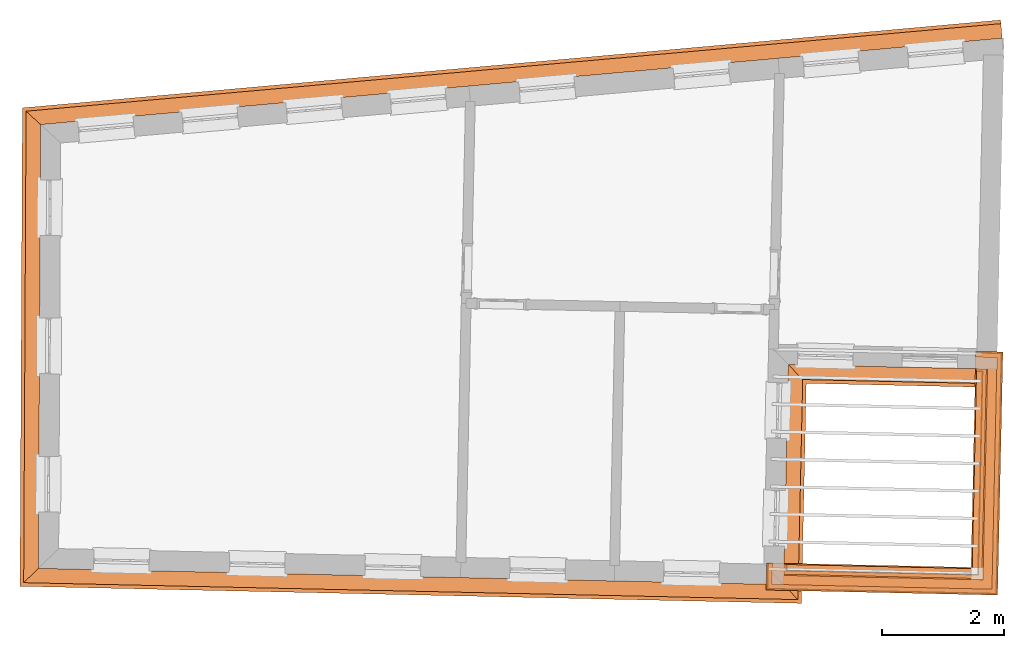
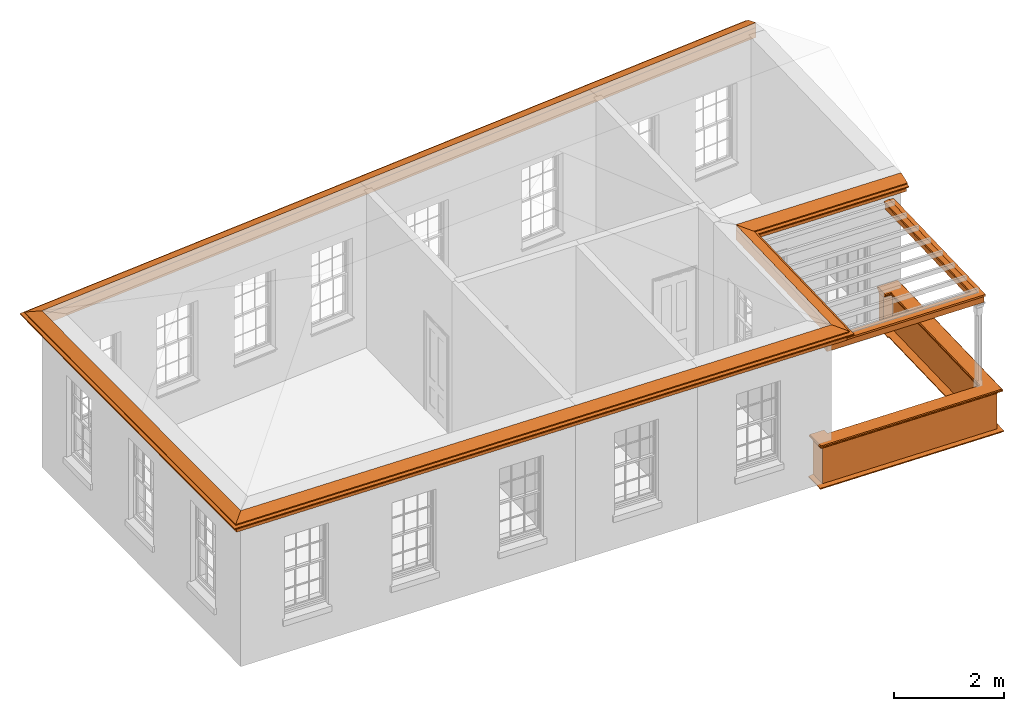
# One storey, part 13 of 14: 7 proxies.
"""IFC2X3 building model written with IfcOpenShell, lengths in metres."""

from ifc_helpers import new_model, entity, si_unit, frame, origin, place, context, subcontext, project, spatial, element, save


model = new_model("IFC2X3")

# Units and contexts
model_context = context("Model", 3, world=origin())
body_context = subcontext(model_context, "Body", "Model", "MODEL_VIEW")
ifc_project = project(units=[si_unit("PLANEANGLEUNIT", "RADIAN"), si_unit("MASSUNIT", "GRAM", prefix="KILO"), si_unit("FORCEUNIT", "NEWTON", prefix="KILO"), si_unit("LENGTHUNIT", "METRE")], contexts=[model_context])

# Site, building, storey
site_placement = place(None, origin())
site = spatial("IfcSite", under=ifc_project, at=site_placement, CompositionType="ELEMENT")
building_placement = place(None, origin())
building = spatial("IfcBuilding", under=site, at=building_placement, Name="Building plot-17", CompositionType="ELEMENT")
storey_placement = place(None, frame((0.0, 0.0, 6.15)))
storey = spatial("IfcBuildingStorey", under=building, at=storey_placement, Name="Floor 1", CompositionType="ELEMENT", Elevation=6.15)

# Proxies
proxy_1_placement = place(storey_placement, frame((0.0, 0.0, 3.45)))
axis2_placement3_d_1 = entity("IfcAxis2Placement3D", entity("IfcCartesianPoint", [0.0, 0.0, 0.0]))
element("IfcBuildingElementProxy", 1, at=proxy_1_placement, inside=storey, Name="eaves", CompositionType="ELEMENT", context=body_context, shape_type="SweptSolid", held_by="IfcProductRepresentation", body=[
    entity("IfcSurfaceCurveSweptAreaSolid", entity("IfcArbitraryClosedProfileDef", "AREA", None, entity("IfcPolyline", [entity("IfcCartesianPoint", [-0.11, 0.25]), entity("IfcCartesianPoint", [-0.33, 0.25]), entity("IfcCartesianPoint", [-0.33, 0.265]), entity("IfcCartesianPoint", [-0.318, 0.268]), entity("IfcCartesianPoint", [-0.309, 0.274]), entity("IfcCartesianPoint", [-0.303, 0.283]), entity("IfcCartesianPoint", [-0.3, 0.295]), entity("IfcCartesianPoint", [-0.285, 0.295]), entity("IfcCartesianPoint", [-0.285, 0.455]), entity("IfcCartesianPoint", [-0.205, 0.455]), entity("IfcCartesianPoint", [-0.205, 0.47]), entity("IfcCartesianPoint", [-0.19, 0.47]), entity("IfcCartesianPoint", [-0.189, 0.483]), entity("IfcCartesianPoint", [-0.186, 0.494]), entity("IfcCartesianPoint", [-0.179, 0.506]), entity("IfcCartesianPoint", [-0.17, 0.514]), entity("IfcCartesianPoint", [-0.16, 0.52]), entity("IfcCartesianPoint", [-0.149, 0.529]), entity("IfcCartesianPoint", [-0.143, 0.539]), entity("IfcCartesianPoint", [-0.14, 0.55]), entity("IfcCartesianPoint", [-0.12, 0.55]), entity("IfcCartesianPoint", [-0.11, 0.48]), entity("IfcCartesianPoint", [-0.11, 0.25])])), axis2_placement3_d_1, entity("IfcPolyline", [entity("IfcCartesianPoint", [86.1735333873012, 26.9244980470085]), entity("IfcCartesianPoint", [70.6604159338027, 25.5310649283099]), entity("IfcCartesianPoint", [70.6259364838392, 18.7410401401183]), entity("IfcCartesianPoint", [82.327616740338, 18.4850974377815]), entity("IfcCartesianPoint", [82.4063929700334, 22.086740474646]), entity("IfcCartesianPoint", [86.0675204491048, 22.0066631831756])]), 0.0, 1.0, entity("IfcPlane", axis2_placement3_d_1)),
])
proxy_2_placement = place(storey_placement, frame((0.0, 0.0, 3.45)))
axis2_placement3_d_2 = entity("IfcAxis2Placement3D", entity("IfcCartesianPoint", [0.0, 0.0, 0.0]))
element("IfcBuildingElementProxy", 2, at=proxy_2_placement, inside=storey, Name="eaves", CompositionType="ELEMENT", context=body_context, shape_type="SweptSolid", held_by="IfcProductRepresentation", body=[
    entity("IfcSurfaceCurveSweptAreaSolid", entity("IfcArbitraryClosedProfileDef", "AREA", None, entity("IfcPolyline", [entity("IfcCartesianPoint", [-0.11, 0.25]), entity("IfcCartesianPoint", [-0.11, 0.48]), entity("IfcCartesianPoint", [-0.08, 0.49]), entity("IfcCartesianPoint", [0.0, 0.25]), entity("IfcCartesianPoint", [-0.11, 0.25])])), axis2_placement3_d_2, entity("IfcPolyline", [entity("IfcCartesianPoint", [86.1735333873012, 26.9244980470085]), entity("IfcCartesianPoint", [70.6604159338027, 25.5310649283099]), entity("IfcCartesianPoint", [70.6259364838392, 18.7410401401183]), entity("IfcCartesianPoint", [82.327616740338, 18.4850974377815]), entity("IfcCartesianPoint", [82.4063929700334, 22.086740474646]), entity("IfcCartesianPoint", [86.0675204491048, 22.0066631831756])]), 0.0, 1.0, entity("IfcPlane", axis2_placement3_d_2)),
])
proxy_3_placement = place(storey_placement, origin())
axis2_placement3_d_3 = entity("IfcAxis2Placement3D", entity("IfcCartesianPoint", [0.0, 0.0, 0.0]))
element("IfcBuildingElementProxy", 3, at=proxy_3_placement, inside=storey, Name="parapet", CompositionType="ELEMENT", context=body_context, shape_type="SweptSolid", held_by="IfcProductRepresentation", body=[
    entity("IfcSurfaceCurveSweptAreaSolid", entity("IfcArbitraryClosedProfileDef", "AREA", None, entity("IfcPolyline", [entity("IfcCartesianPoint", [0.0, 0.25]), entity("IfcCartesianPoint", [0.795, 0.25]), entity("IfcCartesianPoint", [0.795, 0.09]), entity("IfcCartesianPoint", [0.02, 0.09]), entity("IfcCartesianPoint", [0.02, -0.08]), entity("IfcCartesianPoint", [0.0, -0.08]), entity("IfcCartesianPoint", [0.0, 0.25])])), axis2_placement3_d_3, entity("IfcPolyline", [entity("IfcCartesianPoint", [82.6397293226527, 18.5782947336697]), entity("IfcCartesianPoint", [82.6375426152953, 18.4783186449738]), entity("IfcCartesianPoint", [85.7388039976697, 18.4104869147044]), entity("IfcCartesianPoint", [85.8108014345573, 21.7022040766116]), entity("IfcCartesianPoint", [85.7108253458614, 21.7043907839689])]), 0.0, 1.0, entity("IfcPlane", axis2_placement3_d_3)),
])
proxy_4_placement = place(storey_placement, origin())
axis2_placement3_d_4 = entity("IfcAxis2Placement3D", entity("IfcCartesianPoint", [0.0, 0.0, 0.0]))
element("IfcBuildingElementProxy", 4, at=proxy_4_placement, inside=storey, Name="parapet", CompositionType="ELEMENT", context=body_context, shape_type="SweptSolid", held_by="IfcProductRepresentation", body=[
    entity("IfcSurfaceCurveSweptAreaSolid", entity("IfcArbitraryClosedProfileDef", "AREA", None, entity("IfcPolyline", [entity("IfcCartesianPoint", [0.795, 0.265]), entity("IfcCartesianPoint", [0.807, 0.268]), entity("IfcCartesianPoint", [0.816, 0.274]), entity("IfcCartesianPoint", [0.822, 0.283]), entity("IfcCartesianPoint", [0.825, 0.295]), entity("IfcCartesianPoint", [0.84, 0.295]), entity("IfcCartesianPoint", [0.84, 0.305]), entity("IfcCartesianPoint", [0.842, 0.317]), entity("IfcCartesianPoint", [0.849, 0.326]), entity("IfcCartesianPoint", [0.858, 0.333]), entity("IfcCartesianPoint", [0.87, 0.335]), entity("IfcCartesianPoint", [0.882, 0.333]), entity("IfcCartesianPoint", [0.891, 0.326]), entity("IfcCartesianPoint", [0.898, 0.317]), entity("IfcCartesianPoint", [0.9, 0.305]), entity("IfcCartesianPoint", [0.9, 0.035]), entity("IfcCartesianPoint", [0.898, 0.023]), entity("IfcCartesianPoint", [0.891, 0.014]), entity("IfcCartesianPoint", [0.882, 0.007]), entity("IfcCartesianPoint", [0.87, 0.005]), entity("IfcCartesianPoint", [0.858, 0.007]), entity("IfcCartesianPoint", [0.849, 0.014]), entity("IfcCartesianPoint", [0.842, 0.023]), entity("IfcCartesianPoint", [0.84, 0.035]), entity("IfcCartesianPoint", [0.84, 0.045]), entity("IfcCartesianPoint", [0.825, 0.045]), entity("IfcCartesianPoint", [0.822, 0.057]), entity("IfcCartesianPoint", [0.816, 0.066]), entity("IfcCartesianPoint", [0.807, 0.072]), entity("IfcCartesianPoint", [0.795, 0.075]), entity("IfcCartesianPoint", [0.795, 0.265])])), axis2_placement3_d_4, entity("IfcPolyline", [entity("IfcCartesianPoint", [82.6397293226527, 18.5782947336697]), entity("IfcCartesianPoint", [82.6375426152953, 18.4783186449738]), entity("IfcCartesianPoint", [85.7388039976697, 18.4104869147044]), entity("IfcCartesianPoint", [85.8108014345573, 21.7022040766116]), entity("IfcCartesianPoint", [85.7108253458614, 21.7043907839689])]), 0.0, 1.0, entity("IfcPlane", axis2_placement3_d_4)),
])
proxy_5_placement = place(storey_placement, origin())
axis2_placement3_d_5 = entity("IfcAxis2Placement3D", entity("IfcCartesianPoint", [0.0, 0.0, 0.0]))
element("IfcBuildingElementProxy", 5, at=proxy_5_placement, inside=storey, Name="parapet", CompositionType="ELEMENT", context=body_context, shape_type="SweptSolid", held_by="IfcProductRepresentation", body=[
    entity("IfcSurfaceCurveSweptAreaSolid", entity("IfcArbitraryClosedProfileDef", "AREA", None, entity("IfcPolyline", [entity("IfcCartesianPoint", [-0.1, 0.25]), entity("IfcCartesianPoint", [-0.1, 0.265]), entity("IfcCartesianPoint", [-0.085, 0.265]), entity("IfcCartesianPoint", [-0.084, 0.278]), entity("IfcCartesianPoint", [-0.081, 0.289]), entity("IfcCartesianPoint", [-0.074, 0.301]), entity("IfcCartesianPoint", [-0.065, 0.309]), entity("IfcCartesianPoint", [-0.055, 0.315]), entity("IfcCartesianPoint", [-0.044, 0.324]), entity("IfcCartesianPoint", [-0.038, 0.334]), entity("IfcCartesianPoint", [-0.035, 0.345]), entity("IfcCartesianPoint", [-0.015, 0.345]), entity("IfcCartesianPoint", [0.0, 0.25]), entity("IfcCartesianPoint", [-0.1, 0.25])])), axis2_placement3_d_5, entity("IfcPolyline", [entity("IfcCartesianPoint", [82.6397293226527, 18.5782947336697]), entity("IfcCartesianPoint", [82.6375426152953, 18.4783186449738]), entity("IfcCartesianPoint", [85.7388039976697, 18.4104869147044]), entity("IfcCartesianPoint", [85.8108014345573, 21.7022040766116]), entity("IfcCartesianPoint", [85.7108253458614, 21.7043907839689])]), 0.0, 1.0, entity("IfcPlane", axis2_placement3_d_5)),
])
proxy_6_placement = place(storey_placement, frame((0.0, 0.0, 3.45)))
axis2_placement3_d_6 = entity("IfcAxis2Placement3D", entity("IfcCartesianPoint", [0.0, 0.0, 0.0]))
element("IfcBuildingElementProxy", 6, at=proxy_6_placement, inside=storey, Name="pergola beam", CompositionType="ELEMENT", context=body_context, shape_type="SweptSolid", held_by="IfcProductRepresentation", body=[
    entity("IfcSurfaceCurveSweptAreaSolid", entity("IfcArbitraryClosedProfileDef", "AREA", None, entity("IfcPolyline", [entity("IfcCartesianPoint", [-0.7, -0.08]), entity("IfcCartesianPoint", [-0.7, 0.08]), entity("IfcCartesianPoint", [-0.56, 0.08]), entity("IfcCartesianPoint", [-0.56, -0.08]), entity("IfcCartesianPoint", [-0.7, -0.08])])), axis2_placement3_d_6, entity("IfcPolyline", [entity("IfcCartesianPoint", [82.5775569620778, 18.4796306693882]), entity("IfcCartesianPoint", [85.7388039976697, 18.4104869147044]), entity("IfcCartesianPoint", [85.8121134589717, 21.7621897298291])]), 0.0, 1.0, entity("IfcPlane", axis2_placement3_d_6)),
])
proxy_7_placement = place(storey_placement, frame((0.0, 0.0, 3.45)))
axis2_placement3_d_7 = entity("IfcAxis2Placement3D", entity("IfcCartesianPoint", [0.0, 0.0, 0.0]))
element("IfcBuildingElementProxy", 7, at=proxy_7_placement, inside=storey, Name="pergola beam", CompositionType="ELEMENT", context=body_context, shape_type="SweptSolid", held_by="IfcProductRepresentation", body=[
    entity("IfcSurfaceCurveSweptAreaSolid", entity("IfcArbitraryClosedProfileDef", "AREA", None, entity("IfcPolyline", [entity("IfcCartesianPoint", [-0.5, 0.0]), entity("IfcCartesianPoint", [-0.52, -0.1]), entity("IfcCartesianPoint", [-0.56, -0.1]), entity("IfcCartesianPoint", [-0.56, 0.1]), entity("IfcCartesianPoint", [-0.52, 0.1]), entity("IfcCartesianPoint", [-0.5, 0.0])])), axis2_placement3_d_7, entity("IfcPolyline", [entity("IfcCartesianPoint", [82.5775569620778, 18.4796306693882]), entity("IfcCartesianPoint", [85.7388039976697, 18.4104869147044]), entity("IfcCartesianPoint", [85.8121134589717, 21.7621897298291])]), 0.0, 1.0, entity("IfcPlane", axis2_placement3_d_7)),
])

save(model, "model.ifc")
